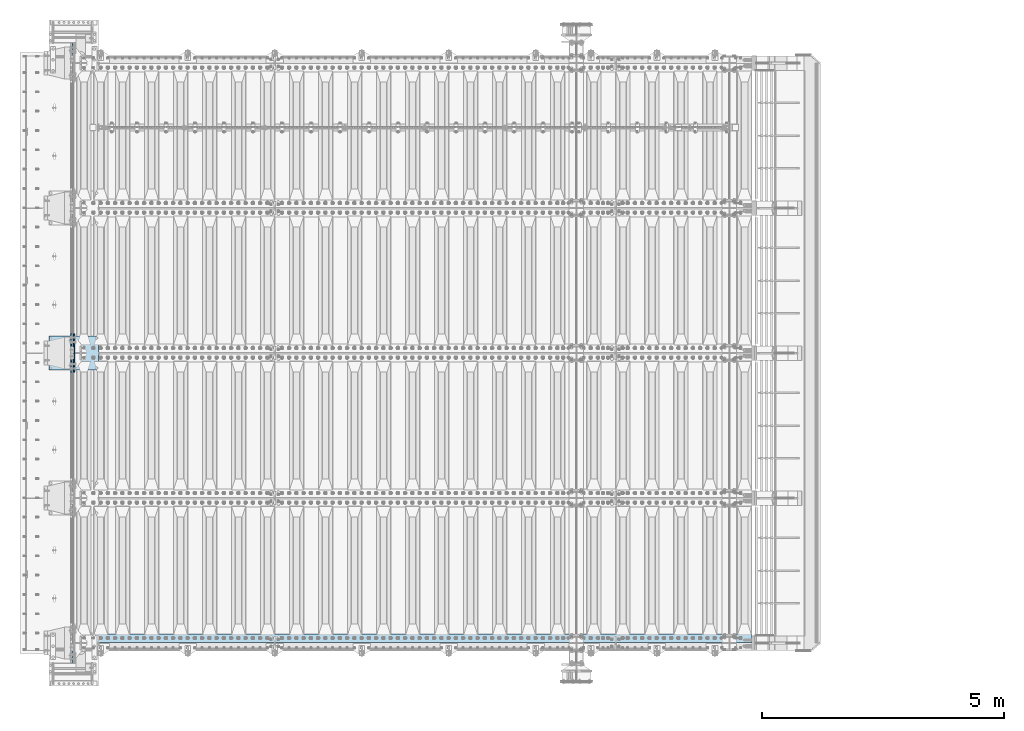
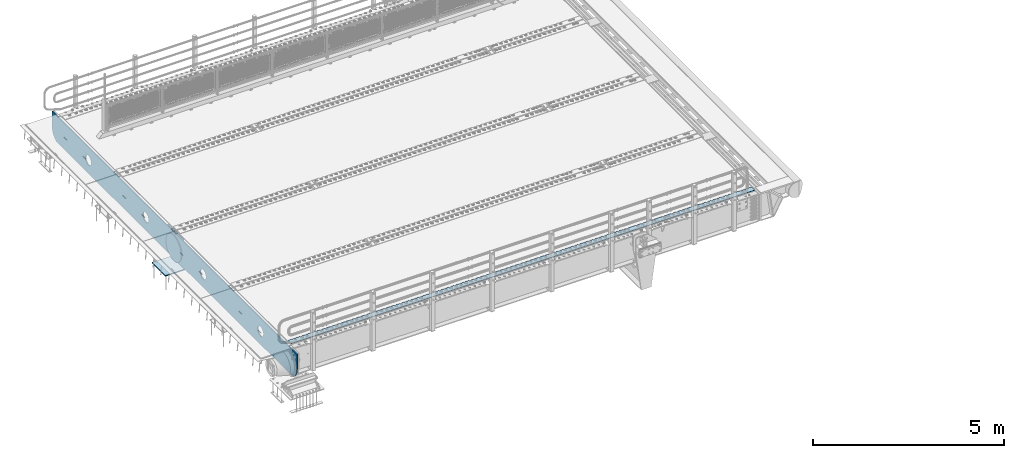
# One storey, part 186 of 240: 5 plates.
"""IFC2X3 building model written with IfcOpenShell, lengths in millimetres."""

from ifc_helpers import new_model, si_unit, frame, origin_with_axes, place, context, subcontext, project, spatial, faceted_brep, material, type_object, element, save


model = new_model("IFC2X3")

# Units and contexts
model_context = context("Model", 3, precision=1e-05, world=origin_with_axes())
body_context = subcontext(model_context, "Body", "Model", "MODEL_VIEW")
ifc_project = project(units=[si_unit("LENGTHUNIT", "METRE", prefix="MILLI"), si_unit("AREAUNIT", "SQUARE_METRE"), si_unit("VOLUMEUNIT", "CUBIC_METRE"), si_unit("MASSUNIT", "GRAM", prefix="KILO"), si_unit("TIMEUNIT", "SECOND"), si_unit("PLANEANGLEUNIT", "RADIAN"), si_unit("SOLIDANGLEUNIT", "STERADIAN"), si_unit("THERMODYNAMICTEMPERATUREUNIT", "DEGREE_CELSIUS"), si_unit("LUMINOUSINTENSITYUNIT", "LUMEN")], contexts=[model_context])

# Site, building, storey
site_placement = place(None, origin_with_axes())
site = spatial("IfcSite", under=ifc_project, at=site_placement, CompositionType="ELEMENT")
building_placement = place(site_placement, origin_with_axes())
building = spatial("IfcBuilding", under=site, at=building_placement, Name="Standard", CompositionType="ELEMENT")
storey_placement = place(building_placement, origin_with_axes())
storey = spatial("IfcBuildingStorey", under=building, at=storey_placement, Name="Undefined", CompositionType="ELEMENT", Elevation=0.0)

# Plates
ifc_material_1 = material(Name="STEEL/S355N")
plate_type_1 = type_object("IfcPlateType", PredefinedType="NOTDEFINED")
plate_1_placement = place(storey_placement, frame((41926.0, 30350.0, -1043.0), z_axis=(1.0, 0.0, 0.0), x_axis=(0.0, -1.0, 0.0)))
element("IfcPlate", 1, at=plate_1_placement, inside=storey, type_object=plate_type_1, material=ifc_material_1, context=body_context, shape_type="Brep", body=[
    faceted_brep([(0.0, -15.0, 0.0), (3.03448323393241e-05, -15.0, 1025.0), (3.03448323393241e-05, 15.0, 1025.0), (0.0, 15.0, 0.0), (700.0, -15.0, 1025.0), (700.0, 15.0, 1025.0), (700.0, -15.0, -7.27595761418343e-12), (700.0, 15.0, -7.27595761418343e-12)], [[[0, 1, 2, 3]], [[1, 4, 5, 2]], [[4, 6, 7, 5]], [[6, 0, 3, 7]], [[5, 7, 3, 2]], [[6, 4, 1, 0]]]),
])
plate_type_2 = type_object("IfcPlateType", PredefinedType="NOTDEFINED")
plate_2_placement = place(storey_placement, frame((42387.5, 30400.0, -114.999999999998), z_axis=(0.0, 0.0, -1.0), x_axis=(0.0, -1.0, 0.0)))
element("IfcPlate", 2, at=plate_2_placement, inside=storey, type_object=plate_type_2, material=ifc_material_1, context=body_context, shape_type="Brep", body=[
    faceted_brep([(0.0, -12.5, 400.0), (2.91645036072441, -12.5, 448.214672101647), (2.91645036072441, 12.5, 448.214672101647), (0.0, 12.5, 400.0), (11.6232730294796, -12.5, 495.726265714562), (11.6232730294796, 12.5, 495.726265714562), (25.9935029256958, -12.5, 541.841954816598), (25.9935029256958, 12.5, 541.841954816598), (45.8175897385445, -12.5, 585.889268817169), (45.8175897385445, 12.5, 585.889268817169), (70.8064536423408, -12.5, 627.22589869221), (70.8064536423408, 12.5, 627.22589869221), (100.595700731341, -12.5, 665.24906329616), (100.595700731341, 12.5, 665.24906329616), (134.750936703451, -12.5, 699.40429926839), (134.750936703451, 12.5, 699.40429926839), (172.774101307281, -12.5, 729.193546357525), (172.774101307281, 12.5, 729.193546357525), (214.11073118222, -12.5, 754.182410261448), (214.11073118222, 12.5, 754.182410261448), (258.158045182681, -12.5, 774.006497074428), (258.158045182681, 12.5, 774.006497074428), (304.273734284623, -12.5, 788.376726970779), (304.273734284623, 12.5, 788.376726970779), (351.785327897465, -12.5, 797.083549639658), (351.785327897465, 12.5, 797.083549639658), (400.0, -12.5, 800.0), (400.0, 12.5, 800.0), (448.21467210335, -12.5, 797.083549637646), (448.21467210335, 12.5, 797.083549637646), (495.726265715995, -12.5, 788.37672696916), (495.726265715995, 12.5, 788.37672696916), (541.841954817748, -12.5, 774.006497073235), (541.841954817748, 12.5, 774.006497073235), (585.889268818006, -12.5, 754.182410260695), (585.889268818006, 12.5, 754.182410260695), (627.225898692734, -12.5, 729.193546357212), (627.225898692734, 12.5, 729.193546357212), (665.24906329636, -12.5, 699.404299268539), (665.24906329636, 12.5, 699.404299268539), (699.404299268259, -12.5, 665.24906329676), (699.404299268259, 12.5, 665.24906329676), (729.193546357063, -12.5, 627.22589869325), (729.193546357063, 12.5, 627.22589869325), (754.18241026067, -12.5, 585.889268818639), (754.18241026067, 12.5, 585.889268818639), (774.006497073351, -12.5, 541.841954818479), (774.006497073351, 12.5, 541.841954818479), (788.376726969393, -12.5, 495.726265716821), (788.376726969393, 12.5, 495.726265716821), (797.083549638002, -12.5, 448.214672104252), (797.083549638002, 12.5, 448.214672104252), (800.0, -12.5, 400.0), (800.0, 12.5, 400.0), (797.083549639283, -12.5, 351.785327898364), (797.083549639283, 12.5, 351.785327898364), (788.376726970528, -12.5, 304.273734285453), (788.376726970528, 12.5, 304.273734285453), (774.006497074311, -12.5, 258.158045183416), (774.006497074311, 12.5, 258.158045183416), (754.182410261463, -12.5, 214.110731182853), (754.182410261463, 12.5, 214.110731182853), (729.193546357659, -12.5, 172.774101307812), (729.193546357659, 12.5, 172.774101307812), (699.404299268659, -12.5, 134.750936703855), (699.404299268659, 12.5, 134.750936703855), (665.249063296564, -12.5, 100.595700731628), (665.249063296564, 12.5, 100.595700731628), (627.225898692719, -12.5, 70.8064536425045), (627.225898692719, 12.5, 70.8064536425045), (585.889268817788, -12.5, 45.8175897385809), (585.889268817788, 12.5, 45.8175897385809), (541.841954817326, -12.5, 25.9935029256012), (541.841954817326, 12.5, 25.9935029256012), (495.726265715377, -12.5, 11.6232730292504), (495.726265715377, 12.5, 11.6232730292504), (448.214672102542, -12.5, 2.91645036037517), (448.214672102542, 12.5, 2.91645036037517), (400.0, -12.5, -5.6843418860808e-14), (400.0, 12.5, -5.6843418860808e-14), (351.785327896665, -12.5, 2.91645036236514), (351.785327896665, 12.5, 2.91645036236514), (304.273734284012, -12.5, 11.6232730308511), (304.273734284012, 12.5, 11.6232730308511), (258.158045182267, -12.5, 25.9935029267763), (258.158045182267, 12.5, 25.9935029267763), (214.110731182009, -12.5, 45.8175897393157), (214.110731182009, 12.5, 45.8175897393157), (172.774101307281, -12.5, 70.8064536427992), (172.774101307281, 12.5, 70.8064536427992), (134.750936703655, -12.5, 100.595700731472), (134.750936703655, 12.5, 100.595700731472), (100.595700731748, -12.5, 134.750936703247), (100.595700731748, 12.5, 134.750936703247), (70.8064536429447, -12.5, 172.774101306761), (70.8064536429447, 12.5, 172.774101306761), (45.8175897393376, -12.5, 214.110731181379), (45.8175897393376, 12.5, 214.110731181379), (25.9935029266635, -12.5, 258.158045181532), (25.9935029266635, 12.5, 258.158045181532), (11.6232730306074, -12.5, 304.273734283186), (11.6232730306074, 12.5, 304.273734283186), (2.9164503619977, -12.5, 351.785327895759), (2.9164503619977, 12.5, 351.785327895759)], [[[0, 1, 2, 3]], [[1, 4, 5, 2]], [[4, 6, 7, 5]], [[6, 8, 9, 7]], [[8, 10, 11, 9]], [[10, 12, 13, 11]], [[12, 14, 15, 13]], [[14, 16, 17, 15]], [[16, 18, 19, 17]], [[18, 20, 21, 19]], [[20, 22, 23, 21]], [[22, 24, 25, 23]], [[24, 26, 27, 25]], [[26, 28, 29, 27]], [[28, 30, 31, 29]], [[30, 32, 33, 31]], [[32, 34, 35, 33]], [[34, 36, 37, 35]], [[36, 38, 39, 37]], [[38, 40, 41, 39]], [[40, 42, 43, 41]], [[42, 44, 45, 43]], [[44, 46, 47, 45]], [[46, 48, 49, 47]], [[48, 50, 51, 49]], [[50, 52, 53, 51]], [[52, 54, 55, 53]], [[54, 56, 57, 55]], [[56, 58, 59, 57]], [[58, 60, 61, 59]], [[60, 62, 63, 61]], [[62, 64, 65, 63]], [[64, 66, 67, 65]], [[66, 68, 69, 67]], [[68, 70, 71, 69]], [[70, 72, 73, 71]], [[72, 74, 75, 73]], [[74, 76, 77, 75]], [[76, 78, 79, 77]], [[78, 80, 81, 79]], [[80, 82, 83, 81]], [[82, 84, 85, 83]], [[84, 86, 87, 85]], [[86, 88, 89, 87]], [[88, 90, 91, 89]], [[90, 92, 93, 91]], [[92, 94, 95, 93]], [[94, 96, 97, 95]], [[96, 98, 99, 97]], [[98, 100, 101, 99]], [[100, 102, 103, 101]], [[102, 0, 3, 103]], [[5, 7, 9, 11, 13, 15, 17, 19, 21, 23, 25, 27, 29, 31, 33, 35, 37, 39, 41, 43, 45, 47, 49, 51, 53, 55, 57, 59, 61, 63, 65, 67, 69, 71, 73, 75, 77, 79, 81, 83, 85, 87, 89, 91, 93, 95, 97, 99, 101, 103, 3, 2]], [[102, 100, 98, 96, 94, 92, 90, 88, 86, 84, 82, 80, 78, 76, 74, 72, 70, 68, 66, 64, 62, 60, 58, 56, 54, 52, 50, 48, 46, 44, 42, 40, 38, 36, 34, 32, 30, 28, 26, 24, 22, 20, 18, 16, 14, 12, 10, 8, 6, 4, 1, 0]]]),
])
ifc_material_2 = material(Name="STEEL/S235JR")
plate_type_3 = type_object("IfcPlateType", PredefinedType="NOTDEFINED")
plate_3_placement = place(storey_placement, frame((56467.0, 24015.0, 20.0), z_axis=(-1.0, 0.0, 0.0), x_axis=(0.0, 1.0, 0.0)))
element("IfcPlate", 3, at=plate_3_placement, inside=storey, type_object=plate_type_3, material=ifc_material_2, context=body_context, shape_type="Brep", body=[
    faceted_brep([(0.0, -6.0, 0.0), (0.0, -6.0, 13997.0), (0.0, 6.0, 13997.0), (0.0, 6.0, 0.0), (170.0, -6.0, 13997.0), (170.0, 6.0, 13997.0), (170.0, -6.0, 0.0), (170.0, 6.0, 0.0)], [[[0, 1, 2, 3]], [[1, 4, 5, 2]], [[4, 6, 7, 5]], [[6, 0, 3, 7]], [[5, 7, 3, 2]], [[6, 4, 1, 0]]]),
])
plate_type_4 = type_object("IfcPlateType", PredefinedType="NOTDEFINED")
plate_4_placement = place(storey_placement, frame((42445.0, 29600.0, -20.0), z_axis=(0.0, 1.0, 0.0), x_axis=(0.0, 0.0, -1.0)))
element("IfcPlate", 4, at=plate_4_placement, inside=storey, type_object=plate_type_4, material=ifc_material_1, context=body_context, shape_type="Brep", body=[
    faceted_brep([(855.0, -15.0, 572.96311467154), (855.0, 15.0, 572.96311467154), (849.182410261294, 15.0, 585.889268817533), (849.182410261294, -15.0, 585.889268817533), (824.193546357474, 15.0, 627.225898692486), (824.193546357474, -15.0, 627.225898692486), (794.404299268454, 15.0, 665.249063296338), (794.404299268454, -15.0, 665.249063296338), (760.249063296334, 15.0, 699.404299268463), (760.249063296334, -15.0, 699.404299268463), (722.22589869248, 15.0, 729.193546357485), (722.22589869248, -15.0, 729.193546357485), (680.889268817528, 15.0, 754.18241026131), (680.889268817528, -15.0, 754.18241026131), (636.841954817037, 15.0, 774.006497074195), (636.841954817037, -15.0, 774.006497074195), (590.726265715048, 15.0, 788.376726970448), (590.726265715048, -15.0, 788.376726970448), (543.214672102156, 15.0, 797.083549639254), (543.214672102156, -15.0, 797.083549639254), (495.0, -15.0, 800.000000000029), (495.0, 15.0, 800.0), (494.999999999412, -15.0, 0.0), (494.999999999412, 15.0, 0.0), (543.214672102129, 15.0, 2.91645036080809), (543.214672102129, -15.0, 2.91645036080809), (590.726265715023, 15.0, 11.6232730296069), (590.726265715023, -15.0, 11.6232730296069), (636.841954817014, 15.0, 25.9935029258631), (636.841954817014, -15.0, 25.9935029258631), (680.889268817507, 15.0, 45.8175897387446), (680.889268817507, -15.0, 45.8175897387446), (722.225898692462, 15.0, 70.8064536425663), (722.225898692462, -15.0, 70.8064536425663), (760.249063296318, 15.0, 100.595700731588), (760.249063296318, -15.0, 100.595700731588), (794.404299268441, 15.0, 134.750936703713), (794.404299268441, -15.0, 134.750936703713), (824.193546357463, 15.0, 172.774101307565), (824.193546357463, -15.0, 172.774101307565), (849.182410261284, 15.0, 214.110731182518), (849.182410261284, -15.0, 214.110731182518), (855.0, -15.0, 227.036885328533), (855.0, 15.0, 227.036885328533), (0.0, -15.0, 0.0), (0.0, 15.0, 0.0), (0.0, 15.0, 800.0), (0.0, -15.0, 800.0)], [[[0, 1, 2, 3]], [[3, 2, 4, 5]], [[5, 4, 6, 7]], [[7, 6, 8, 9]], [[9, 8, 10, 11]], [[11, 10, 12, 13]], [[13, 12, 14, 15]], [[15, 14, 16, 17]], [[17, 16, 18, 19]], [[20, 19, 18, 21]], [[22, 23, 24, 25]], [[25, 24, 26, 27]], [[27, 26, 28, 29]], [[29, 28, 30, 31]], [[31, 30, 32, 33]], [[33, 32, 34, 35]], [[35, 34, 36, 37]], [[37, 36, 38, 39]], [[39, 38, 40, 41]], [[42, 41, 40, 43]], [[42, 43, 1, 0]], [[44, 45, 23, 22]], [[16, 14, 12, 10, 8, 6, 4, 2, 1, 43, 40, 38, 36, 34, 32, 30, 28, 26, 24, 23, 45, 46, 21, 18]], [[44, 47, 46, 45]], [[46, 47, 20, 21]], [[47, 44, 22, 25, 27, 29, 31, 33, 35, 37, 39, 41, 42, 0, 3, 5, 7, 9, 11, 13, 15, 17, 19, 20]]]),
])
plate_type_5 = type_object("IfcPlateType", PredefinedType="NOTDEFINED")
plate_5_placement = place(storey_placement, frame((42415.0, 23600.0, -36.0000190935184), z_axis=(0.0, 1.0, 0.0), x_axis=(0.0, 0.0, -1.0)))
element("IfcPlate", 5, at=plate_5_placement, inside=storey, type_object=plate_type_5, material=ifc_material_1, context=body_context, shape_type="Brep", body=[
    faceted_brep([(449.26354918649, -15.0, 2047.11778936673), (449.26354918649, 15.0, 2047.11778936673), (477.402515687619, 15.0, 2038.58192701411), (477.402515687619, -15.0, 2038.58192701411), (503.335535702627, 15.0, 2024.7204388272), (503.335535702627, -15.0, 2024.7204388272), (526.066017815742, 15.0, 2006.06601402341), (526.066017815742, -15.0, 2006.06601402341), (544.720442346759, 15.0, 1983.33553168645), (544.720442346759, -15.0, 1983.33553168645), (558.581930222472, 15.0, 1957.4025115051), (558.581930222472, -15.0, 1957.4025115051), (567.11779223743, 15.0, 1929.26354490154), (567.11779223743, -15.0, 1929.26354490154), (570.000000001364, 15.0, 1899.99999658183), (570.000000001364, -15.0, 1899.99999658183), (567.117791886267, 15.0, 1870.7364482967), (567.117791886267, -15.0, 1870.7364482967), (558.581929533642, 15.0, 1842.59748179558), (558.581929533642, -15.0, 1842.59748179558), (544.720441346732, 15.0, 1816.66446178057), (544.720441346732, -15.0, 1816.66446178057), (526.06601654295, 15.0, 1793.93397966745), (526.06601654295, -15.0, 1793.93397966745), (503.335534205981, 15.0, 1775.27955513644), (503.335534205981, -15.0, 1775.27955513644), (477.402514024636, 15.0, 1761.41806726072), (477.402514024636, -15.0, 1761.41806726072), (449.263547421076, 15.0, 1752.88220524576), (449.263547421076, -15.0, 1752.88220524576), (419.999999101364, 15.0, 1749.99999748183), (419.999999101364, -15.0, 1749.99999748183), (390.736450816238, 15.0, 1752.88220559692), (390.736450816238, -15.0, 1752.88220559692), (362.597484315109, 15.0, 1761.41806794955), (362.597484315109, -15.0, 1761.41806794955), (336.664464300101, 15.0, 1775.27955613646), (336.664464300101, -15.0, 1775.27955613646), (313.933982186985, 15.0, 1793.93398094024), (313.933982186985, -15.0, 1793.93398094024), (295.279557655969, 15.0, 1816.66446327721), (295.279557655969, -15.0, 1816.66446327721), (281.418069780255, 15.0, 1842.59748345856), (281.418069780255, -15.0, 1842.59748345856), (272.882207765298, 15.0, 1870.73645006212), (272.882207765298, -15.0, 1870.73645006212), (270.000000001364, 15.0, 1899.99999838183), (270.000000001364, -15.0, 1899.99999838183), (272.88220811646, 15.0, 1929.26354666696), (272.88220811646, -15.0, 1929.26354666696), (281.418070469086, 15.0, 1957.40251316808), (281.418070469086, -15.0, 1957.40251316808), (295.279558655995, 15.0, 1983.33553318309), (295.279558655995, -15.0, 1983.33553318309), (313.933983459778, 15.0, 2006.0660152962), (313.933983459778, -15.0, 2006.0660152962), (336.664465796746, 15.0, 2024.72043982722), (336.664465796746, -15.0, 2024.72043982722), (362.597485978092, 15.0, 2038.58192770294), (362.597485978092, -15.0, 2038.58192770294), (390.736452581651, 15.0, 2047.1177897179), (390.736452581651, -15.0, 2047.1177897179), (420.000000901364, 15.0, 2049.99999748183), (420.000000901364, -15.0, 2049.99999748183), (-9.00019287541909e-07, 15.0, 12800.0), (-9.00019287541909e-07, -15.0, 12800.0), (479.000057696533, -15.0, 12799.999997128), (479.000057666522, 15.0, 12800.0), (0.0, -15.0, 0.0), (0.0, 15.0, 0.0), (478.999999999727, 15.0, 0.0), (478.999999999727, -15.0, 0.0), (527.214672105641, 15.0, 2.91645036480986), (527.214672105641, -15.0, 2.91645036480986), (574.726265718119, 15.0, 11.6232730332849), (574.726265718119, -15.0, 11.6232730332849), (620.841954819697, 15.0, 25.9935029291883), (620.841954819697, -15.0, 25.9935029291883), (664.889268819795, 15.0, 45.8175897417095), (664.889268819795, -15.0, 45.8175897417095), (706.22589869437, 15.0, 70.8064536451566), (706.22589869437, -15.0, 70.8064536451566), (744.249063297858, 15.0, 100.595700733797), (744.249063297858, -15.0, 100.595700733797), (778.40429926963, 15.0, 134.750936705532), (778.40429926963, -15.0, 134.750936705532), (808.193546358328, 15.0, 172.774101308991), (808.193546358328, -15.0, 172.774101308991), (833.182410261848, 15.0, 214.110731183562), (833.182410261848, -15.0, 214.110731183562), (838.999998917404, -15.0, 227.036882922963), (838.999998917404, 15.0, 227.036882922963), (838.99994004746, 15.0, 12572.9632668348), (838.99994004746, -15.0, 12572.9632669014), (833.182425776973, 15.0000000000073, 12585.8892544673), (833.182425806973, -15.0, 12585.8892544673), (808.193562546076, 15.0000000000073, 12627.2258861183), (808.193562576076, -15.0, 12627.2258861183), (778.404315799404, 15.0000000000073, 12665.2490524789), (778.404315829404, -15.0, 12665.2490524789), (744.249079855154, 15.0000000000073, 12699.4042901361), (744.249079885154, -15.0, 12699.4042901361), (706.225914988449, 15.0000000000073, 12729.1935387895), (706.225915018449, -15.0, 12729.1935387895), (664.889284590665, 15.0000000000073, 12754.1824040934), (664.889284620665, -15.0, 12754.1824040934), (620.84196984424, 15.0000000000073, 12774.0064921038), (620.84196987424, -15.0, 12774.0064921038), (574.726279815259, 15.0000000000073, 12788.3767229635), (574.726279845259, -15.0, 12788.3767229635), (527.214685140469, 15.0000000000073, 12797.0835463376), (527.214685170468, -15.0, 12797.0835463376), (390.736498878496, -15.0, 11047.1177897179), (390.736498878496, 15.0, 11047.1177897179), (420.000047198208, 15.0, 11049.9999974818), (420.000047198208, -15.0, 11049.9999974818), (362.597532274936, -15.0, 11038.5819277029), (362.597532274936, 15.0, 11038.5819277029), (336.664512093591, -15.0, 11024.7204398272), (336.664512093591, 15.0, 11024.7204398272), (313.934029756622, -15.0, 11006.0660152962), (313.934029756622, 15.0, 11006.0660152962), (295.27960495284, -15.0, 10983.3355331831), (295.27960495284, 15.0, 10983.3355331831), (281.41811676593, -15.0, 10957.4025131681), (281.41811676593, 15.0, 10957.4025131681), (272.882254413305, -15.0, 10929.263546667), (272.882254413305, 15.0, 10929.263546667), (270.000046298208, -15.0, 10899.9999983818), (270.000046298208, 15.0, 10899.9999983818), (272.882254062142, -15.0, 10870.7364500621), (272.882254062142, 15.0, 10870.7364500621), (281.4181160771, -15.0, 10842.5974834586), (281.4181160771, 15.0, 10842.5974834586), (295.279603952813, -15.0, 10816.6644632772), (295.279603952813, 15.0, 10816.6644632772), (313.93402848383, -15.0, 10793.9339809402), (313.93402848383, 15.0, 10793.9339809402), (336.664510596945, -15.0, 10775.2795561365), (336.664510596945, 15.0, 10775.2795561365), (362.597530611953, -15.0, 10761.4180679496), (362.597530611953, 15.0, 10761.4180679496), (390.736497113082, -15.0, 10752.8822055969), (390.736497113082, 15.0, 10752.8822055969), (420.000045398208, -15.0, 10749.9999974818), (420.000045398208, 15.0, 10749.9999974818), (449.263593717921, -15.0, 10752.8822052458), (449.263593717921, 15.0, 10752.8822052458), (477.40256032148, -15.0, 10761.4180672607), (477.40256032148, 15.0, 10761.4180672607), (503.335580502826, -15.0, 10775.2795551364), (503.335580502826, 15.0, 10775.2795551364), (526.066062839794, -15.0, 10793.9339796675), (526.066062839794, 15.0, 10793.9339796675), (544.720487643577, -15.0, 10816.6644617806), (544.720487643577, 15.0, 10816.6644617806), (558.581975830486, -15.0, 10842.5974817956), (558.581975830486, 15.0, 10842.5974817956), (567.117838183112, -15.0, 10870.7364482967), (567.117838183112, 15.0, 10870.7364482967), (570.000046298208, -15.0, 10899.9999965818), (570.000046298208, 15.0, 10899.9999965818), (567.117838534274, -15.0, 10929.2635449015), (567.117838534274, 15.0, 10929.2635449015), (558.581976519316, -15.0, 10957.4025115051), (558.581976519316, 15.0, 10957.4025115051), (544.720488643603, -15.0, 10983.3355316864), (544.720488643603, 15.0, 10983.3355316864), (526.066064112586, -15.0, 11006.0660140234), (526.066064112586, 15.0, 11006.0660140234), (503.335581999471, -15.0, 11024.7204388272), (503.335581999471, 15.0, 11024.7204388272), (477.402561984463, -15.0, 11038.5819270141), (477.402561984463, 15.0, 11038.5819270141), (449.263595483334, -15.0, 11047.1177893667), (449.263595483334, 15.0, 11047.1177893667), (390.736483432996, -14.9999999999927, 8047.1177897179), (390.736483432996, 15.0, 8047.1177897179), (420.000031752709, 15.0, 8049.99999748183), (420.000031752709, -14.9999999999927, 8049.99999748183), (362.597516829437, -14.9999999999927, 8038.58192770294), (362.597516829437, 15.0, 8038.58192770294), (336.664496648091, -14.9999999999927, 8024.72043982722), (336.664496648091, 15.0, 8024.72043982722), (313.934014311123, -14.9999999999927, 8006.0660152962), (313.934014311123, 15.0, 8006.0660152962), (295.27958950734, -14.9999999999927, 7983.33553318309), (295.27958950734, 15.0, 7983.33553318309), (281.418101320431, -14.9999999999927, 7957.40251316808), (281.418101320431, 15.0, 7957.40251316808), (272.882238967805, -14.9999999999927, 7929.26354666696), (272.882238967805, 15.0, 7929.26354666696), (270.000030852709, -14.9999999999927, 7899.99999838183), (270.000030852709, 15.0, 7899.99999838183), (272.882238616643, -14.9999999999927, 7870.73645006212), (272.882238616643, 15.0, 7870.73645006212), (281.418100631601, -14.9999999999927, 7842.59748345856), (281.418100631601, 15.0, 7842.59748345856), (295.279588507314, -14.9999999999927, 7816.66446327721), (295.279588507314, 15.0, 7816.66446327721), (313.93401303833, -14.9999999999927, 7793.93398094024), (313.93401303833, 15.0, 7793.93398094024), (336.664495151446, -14.9999999999927, 7775.27955613646), (336.664495151446, 15.0, 7775.27955613646), (362.597515166453, -14.9999999999927, 7761.41806794955), (362.597515166453, 15.0, 7761.41806794955), (390.736481667583, -14.9999999999927, 7752.88220559692), (390.736481667583, 15.0, 7752.88220559692), (420.000029952709, -14.9999999999927, 7749.99999748183), (420.000029952709, 15.0, 7749.99999748183), (449.263578272421, -14.9999999999927, 7752.88220524576), (449.263578272421, 15.0, 7752.88220524576), (477.402544875981, -14.9999999999927, 7761.41806726072), (477.402544875981, 15.0, 7761.41806726072), (503.335565057326, -14.9999999999927, 7775.27955513644), (503.335565057326, 15.0, 7775.27955513644), (526.066047394295, -14.9999999999927, 7793.93397966745), (526.066047394295, 15.0, 7793.93397966745), (544.720472198077, -14.9999999999927, 7816.66446178057), (544.720472198077, 15.0, 7816.66446178057), (558.581960384986, -14.9999999999927, 7842.59748179558), (558.581960384986, 15.0, 7842.59748179558), (567.117822737612, -14.9999999999927, 7870.7364482967), (567.117822737612, 15.0, 7870.7364482967), (570.000030852709, -14.9999999999927, 7899.99999658183), (570.000030852709, 15.0, 7899.99999658183), (567.117823088774, -14.9999999999927, 7929.26354490154), (567.117823088774, 15.0, 7929.26354490154), (558.581961073817, -14.9999999999927, 7957.4025115051), (558.581961073817, 15.0, 7957.4025115051), (544.720473198104, -14.9999999999927, 7983.33553168645), (544.720473198104, 15.0, 7983.33553168645), (526.066048667087, -14.9999999999927, 8006.06601402341), (526.066048667087, 15.0, 8006.06601402341), (503.335566553971, -14.9999999999927, 8024.7204388272), (503.335566553971, 15.0, 8024.7204388272), (477.402546538964, -14.9999999999927, 8038.58192701411), (477.402546538964, 15.0, 8038.58192701411), (449.263580037835, -14.9999999999927, 8047.11778936673), (449.263580037835, 15.0, 8047.11778936673), (477.402531106682, -15.0, 5038.58192701411), (503.33555112169, -15.0, 5024.7204388272), (526.066033234805, -15.0, 5006.06601402341), (544.720457765822, -15.0, 4983.33553168645), (558.581945641535, -15.0, 4957.4025115051), (567.117807656493, -15.0, 4929.26354490154), (570.000015420427, -15.0, 4899.99999658183), (567.11780730533, -15.0, 4870.7364482967), (558.581944952705, -15.0, 4842.59748179558), (544.720456765796, -15.0, 4816.66446178057), (526.066031962013, -15.0, 4793.93397966745), (503.335549625045, -15.0, 4775.27955513644), (477.402529443699, -15.0, 4761.41806726072), (449.26356284014, -15.0, 4752.88220524576), (420.000014520427, -15.0, 4749.99999748183), (390.736466235301, -15.0, 4752.88220559692), (362.597499734172, -15.0, 4761.41806794955), (336.664479719164, -15.0, 4775.27955613646), (313.933997606049, -15.0, 4793.93398094024), (295.279573075032, -15.0, 4816.66446327721), (281.418085199319, -15.0, 4842.59748345856), (272.882223184361, -15.0, 4870.73645006212), (270.000015420427, -15.0, 4899.99999838183), (272.882223535524, -15.0, 4929.26354666696), (281.418085888149, -15.0, 4957.40251316808), (295.279574075059, -15.0, 4983.33553318309), (313.933998878841, -15.0, 5006.0660152962), (336.664481215809, -15.0, 5024.72043982722), (362.597501397155, -15.0, 5038.58192770294), (390.736468000715, -15.0, 5047.1177897179), (420.000016320427, -15.0, 5049.99999748183), (449.263564605553, -15.0, 5047.11778936673), (362.597501397155, 15.0, 5038.58192770294), (390.736468000715, 15.0, 5047.1177897179), (336.664481215809, 15.0, 5024.72043982722), (313.933998878841, 15.0, 5006.0660152962), (295.279574075059, 15.0, 4983.33553318309), (281.418085888149, 15.0, 4957.40251316808), (272.882223535524, 15.0, 4929.26354666696), (270.000015420427, 15.0, 4899.99999838183), (272.882223184361, 15.0, 4870.73645006212), (281.418085199319, 15.0, 4842.59748345856), (295.279573075032, 15.0, 4816.66446327721), (313.933997606049, 15.0, 4793.93398094024), (336.664479719164, 15.0, 4775.27955613646), (362.597499734172, 15.0, 4761.41806794955), (390.736466235301, 15.0, 4752.88220559692), (420.000014520427, 15.0, 4749.99999748183), (449.26356284014, 15.0, 4752.88220524576), (477.402529443699, 15.0, 4761.41806726072), (503.335549625045, 15.0, 4775.27955513644), (526.066031962013, 15.0, 4793.93397966745), (544.720456765796, 15.0, 4816.66446178057), (558.581944952705, 15.0, 4842.59748179558), (567.11780730533, 15.0, 4870.7364482967), (570.000015420427, 15.0, 4899.99999658183), (567.117807656493, 15.0, 4929.26354490154), (558.581945641535, 15.0, 4957.4025115051), (544.720457765822, 15.0, 4983.33553168645), (526.066033234805, 15.0, 5006.06601402341), (503.33555112169, 15.0, 5024.7204388272), (477.402531106682, 15.0, 5038.58192701411), (449.263564605553, 15.0, 5047.11778936673), (420.000016320427, 15.0, 5049.99999748183)], [[[0, 1, 2, 3]], [[3, 2, 4, 5]], [[5, 4, 6, 7]], [[7, 6, 8, 9]], [[9, 8, 10, 11]], [[11, 10, 12, 13]], [[13, 12, 14, 15]], [[15, 14, 16, 17]], [[17, 16, 18, 19]], [[19, 18, 20, 21]], [[21, 20, 22, 23]], [[23, 22, 24, 25]], [[25, 24, 26, 27]], [[27, 26, 28, 29]], [[29, 28, 30, 31]], [[31, 30, 32, 33]], [[33, 32, 34, 35]], [[35, 34, 36, 37]], [[37, 36, 38, 39]], [[39, 38, 40, 41]], [[41, 40, 42, 43]], [[43, 42, 44, 45]], [[45, 44, 46, 47]], [[47, 46, 48, 49]], [[49, 48, 50, 51]], [[51, 50, 52, 53]], [[53, 52, 54, 55]], [[55, 54, 56, 57]], [[57, 56, 58, 59]], [[59, 58, 60, 61]], [[61, 60, 62, 63]], [[63, 62, 1, 0]], [[64, 65, 66, 67]], [[68, 65, 64, 69]], [[68, 69, 70, 71]], [[71, 70, 72, 73]], [[73, 72, 74, 75]], [[75, 74, 76, 77]], [[77, 76, 78, 79]], [[79, 78, 80, 81]], [[81, 80, 82, 83]], [[83, 82, 84, 85]], [[85, 84, 86, 87]], [[87, 86, 88, 89]], [[90, 89, 88, 91]], [[90, 91, 92, 93]], [[93, 92, 94, 95]], [[95, 94, 96, 97]], [[97, 96, 98, 99]], [[99, 98, 100, 101]], [[101, 100, 102, 103]], [[103, 102, 104, 105]], [[105, 104, 106, 107]], [[107, 106, 108, 109]], [[109, 108, 110, 111]], [[66, 111, 110, 67]], [[112, 113, 114, 115]], [[116, 117, 113, 112]], [[118, 119, 117, 116]], [[120, 121, 119, 118]], [[122, 123, 121, 120]], [[124, 125, 123, 122]], [[126, 127, 125, 124]], [[128, 129, 127, 126]], [[130, 131, 129, 128]], [[132, 133, 131, 130]], [[134, 135, 133, 132]], [[136, 137, 135, 134]], [[138, 139, 137, 136]], [[140, 141, 139, 138]], [[142, 143, 141, 140]], [[144, 145, 143, 142]], [[146, 147, 145, 144]], [[148, 149, 147, 146]], [[150, 151, 149, 148]], [[152, 153, 151, 150]], [[154, 155, 153, 152]], [[156, 157, 155, 154]], [[158, 159, 157, 156]], [[160, 161, 159, 158]], [[162, 163, 161, 160]], [[164, 165, 163, 162]], [[166, 167, 165, 164]], [[168, 169, 167, 166]], [[170, 171, 169, 168]], [[172, 173, 171, 170]], [[174, 175, 173, 172]], [[115, 114, 175, 174]], [[176, 177, 178, 179]], [[180, 181, 177, 176]], [[182, 183, 181, 180]], [[184, 185, 183, 182]], [[186, 187, 185, 184]], [[188, 189, 187, 186]], [[190, 191, 189, 188]], [[192, 193, 191, 190]], [[194, 195, 193, 192]], [[196, 197, 195, 194]], [[198, 199, 197, 196]], [[200, 201, 199, 198]], [[202, 203, 201, 200]], [[204, 205, 203, 202]], [[206, 207, 205, 204]], [[208, 209, 207, 206]], [[210, 211, 209, 208]], [[212, 213, 211, 210]], [[214, 215, 213, 212]], [[216, 217, 215, 214]], [[218, 219, 217, 216]], [[220, 221, 219, 218]], [[222, 223, 221, 220]], [[224, 225, 223, 222]], [[226, 227, 225, 224]], [[228, 229, 227, 226]], [[230, 231, 229, 228]], [[232, 233, 231, 230]], [[234, 235, 233, 232]], [[236, 237, 235, 234]], [[238, 239, 237, 236]], [[179, 178, 239, 238]], [[65, 68, 71, 73, 75, 77, 79, 81, 83, 85, 87, 89, 90, 93, 95, 97, 99, 101, 103, 105, 107, 109, 111, 66], [3, 5, 7, 9, 11, 13, 15, 17, 19, 21, 23, 25, 27, 29, 31, 33, 35, 37, 39, 41, 43, 45, 47, 49, 51, 53, 55, 57, 59, 61, 63, 0], [240, 241, 242, 243, 244, 245, 246, 247, 248, 249, 250, 251, 252, 253, 254, 255, 256, 257, 258, 259, 260, 261, 262, 263, 264, 265, 266, 267, 268, 269, 270, 271], [236, 234, 232, 230, 228, 226, 224, 222, 220, 218, 216, 214, 212, 210, 208, 206, 204, 202, 200, 198, 196, 194, 192, 190, 188, 186, 184, 182, 180, 176, 179, 238], [172, 170, 168, 166, 164, 162, 160, 158, 156, 154, 152, 150, 148, 146, 144, 142, 140, 138, 136, 134, 132, 130, 128, 126, 124, 122, 120, 118, 116, 112, 115, 174]], [[268, 272, 273, 269]], [[267, 274, 272, 268]], [[266, 275, 274, 267]], [[265, 276, 275, 266]], [[264, 277, 276, 265]], [[263, 278, 277, 264]], [[262, 279, 278, 263]], [[261, 280, 279, 262]], [[260, 281, 280, 261]], [[259, 282, 281, 260]], [[258, 283, 282, 259]], [[257, 284, 283, 258]], [[256, 285, 284, 257]], [[255, 286, 285, 256]], [[254, 287, 286, 255]], [[253, 288, 287, 254]], [[252, 289, 288, 253]], [[251, 290, 289, 252]], [[250, 291, 290, 251]], [[249, 292, 291, 250]], [[248, 293, 292, 249]], [[247, 294, 293, 248]], [[246, 295, 294, 247]], [[245, 296, 295, 246]], [[244, 297, 296, 245]], [[243, 298, 297, 244]], [[242, 299, 298, 243]], [[241, 300, 299, 242]], [[240, 301, 300, 241]], [[271, 302, 301, 240]], [[270, 303, 302, 271]], [[269, 273, 303, 270]], [[108, 106, 104, 102, 100, 98, 96, 94, 92, 91, 88, 86, 84, 82, 80, 78, 76, 74, 72, 70, 69, 64, 67, 110], [58, 56, 54, 52, 50, 48, 46, 44, 42, 40, 38, 36, 34, 32, 30, 28, 26, 24, 22, 20, 18, 16, 14, 12, 10, 8, 6, 4, 2, 1, 62, 60], [272, 274, 275, 276, 277, 278, 279, 280, 281, 282, 283, 284, 285, 286, 287, 288, 289, 290, 291, 292, 293, 294, 295, 296, 297, 298, 299, 300, 301, 302, 303, 273], [181, 183, 185, 187, 189, 191, 193, 195, 197, 199, 201, 203, 205, 207, 209, 211, 213, 215, 217, 219, 221, 223, 225, 227, 229, 231, 233, 235, 237, 239, 178, 177], [117, 119, 121, 123, 125, 127, 129, 131, 133, 135, 137, 139, 141, 143, 145, 147, 149, 151, 153, 155, 157, 159, 161, 163, 165, 167, 169, 171, 173, 175, 114, 113]]]),
])

save(model, "model.ifc")
